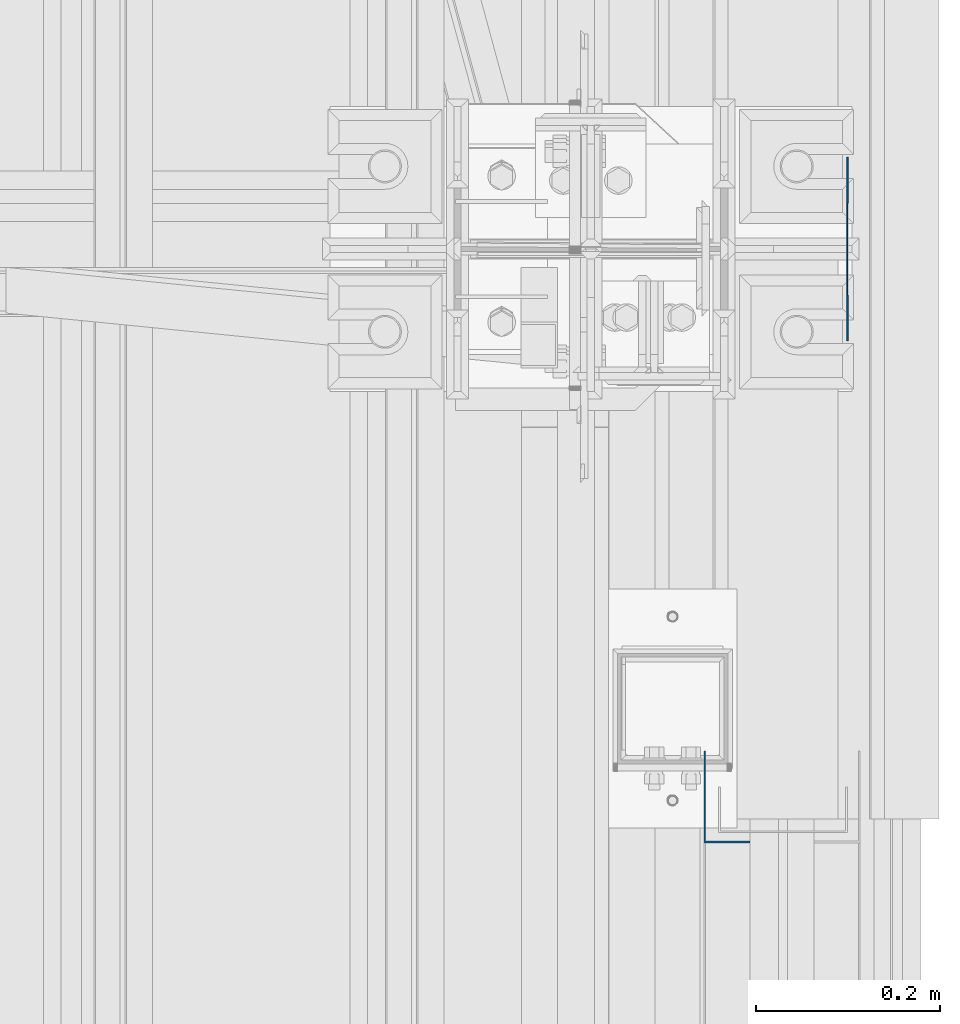
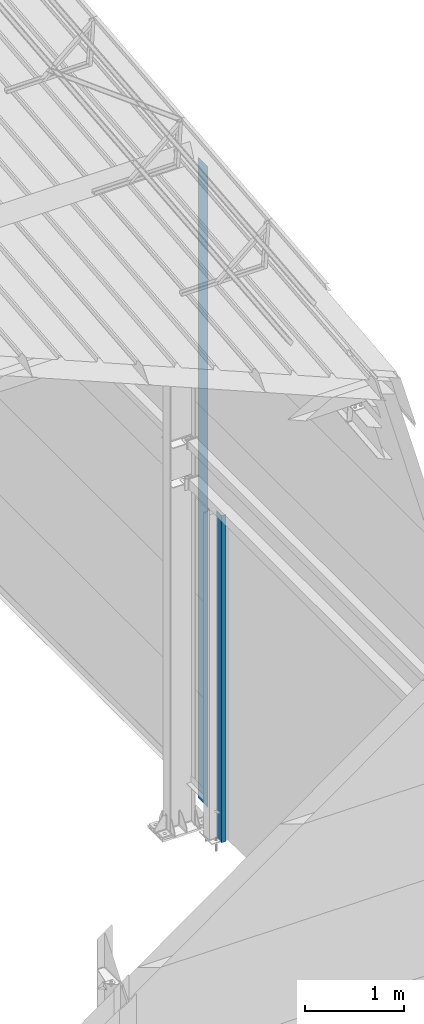
# One storey, part 13 of 709: 2 columns, 2 elements without a shape of their own.
"""IFC4 building model written with IfcOpenShell, lengths in millimetres."""

from ifc_helpers import new_model, si_unit, direction, frame, origin_with_axes, place, context, subcontext, project, spatial, line, indexed_curve, outline, extrude, material, element, aggregate, save


model = new_model("IFC4")

# Units and contexts
model_context = context("Model", 3, precision=0.2, world=origin_with_axes(), true_north=direction((0.0, 1.0)))
body_context = subcontext(model_context, "Body", "Model", "MODEL_VIEW")
ifc_project = project(units=[si_unit("LENGTHUNIT", "METRE", prefix="MILLI"), si_unit("AREAUNIT", "SQUARE_METRE"), si_unit("VOLUMEUNIT", "CUBIC_METRE"), si_unit("MASSUNIT", "GRAM", prefix="KILO"), si_unit("TIMEUNIT", "SECOND"), si_unit("PLANEANGLEUNIT", "RADIAN"), si_unit("SOLIDANGLEUNIT", "STERADIAN"), si_unit("THERMODYNAMICTEMPERATUREUNIT", "DEGREE_CELSIUS"), si_unit("LUMINOUSINTENSITYUNIT", "LUMEN")], contexts=[model_context])

# Site, building, storey
site_placement = place(None, origin_with_axes())
site = spatial("IfcSite", under=ifc_project, at=site_placement, CompositionType="ELEMENT")
building_placement = place(site_placement, origin_with_axes())
building = spatial("IfcBuilding", under=site, at=building_placement, Name="Undefined", CompositionType="ELEMENT")
storey_placement = place(building_placement, origin_with_axes())
storey = spatial("IfcBuildingStorey", under=building, at=storey_placement, Name="Undefined", CompositionType="ELEMENT", Elevation=0.0)

# Assembly, column
assembly_1_placement = place(storey_placement, frame((49999.0, 4855.0, -50.0), z_axis=(-1.0, 0.0, 0.0), x_axis=(0.0, 0.0, 1.0)))
assembly_1 = element("IfcElementAssembly", 1, at=assembly_1_placement, inside=storey)
ifc_material = material(Name="Steel_Undefined", Category="STEEL")
column_1_placement = place(assembly_1_placement, origin_with_axes())
column_1 = element("IfcColumn", 2, at=column_1_placement, material=ifc_material, context=body_context, shape_type="SolidModel", body=[
    extrude(outline(indexed_curve([(-25.0, -1.0), (25.0, -1.0), (25.0, 99.0), (23.0, 99.0), (23.0, 1.0), (-25.0, 1.0)], segments=[line(1, 2, 3, 4, 5, 6, 1)])), frame((0.0, 0.0, 0.0), z_axis=(-1.0, 0.0, 0.0), x_axis=(0.0, 0.0, 1.0)), (0.0, 0.0, -1.0), 4050.0),
])
aggregate(assembly_1, [column_1])

assembly_2_placement = place(storey_placement, frame((50130.0, 5500.0, 0.0), z_axis=(1.0, 0.0, 0.0), x_axis=(0.0, 0.0, 1.0)))
assembly_2 = element("IfcElementAssembly", 3, at=assembly_2_placement, inside=storey)
column_2_placement = place(assembly_2_placement, origin_with_axes())
column_2 = element("IfcColumn", 4, at=column_2_placement, material=ifc_material, context=body_context, shape_type="SolidModel", body=[
    extrude(outline(indexed_curve([(-0.375, -100.0), (1.245, -100.0), (1.245, -50.0), (0.495, -50.0), (0.495, -99.25), (0.375, -99.25), (0.375, 99.25), (0.495, 99.25), (0.495, 50.0), (1.245, 50.0), (1.245, 100.0), (-0.375, 100.0)], segments=[line(1, 2, 3, 4, 5, 6, 7, 8, 9, 10, 11, 12, 1)])), frame((0.0, 0.0, 0.0), z_axis=(-1.0, 0.0, 0.0), x_axis=(0.0, 0.0, 1.0)), (0.0, 0.0, -1.0), 7929.67111),
])
aggregate(assembly_2, [column_2])

save(model, "model.ifc")
